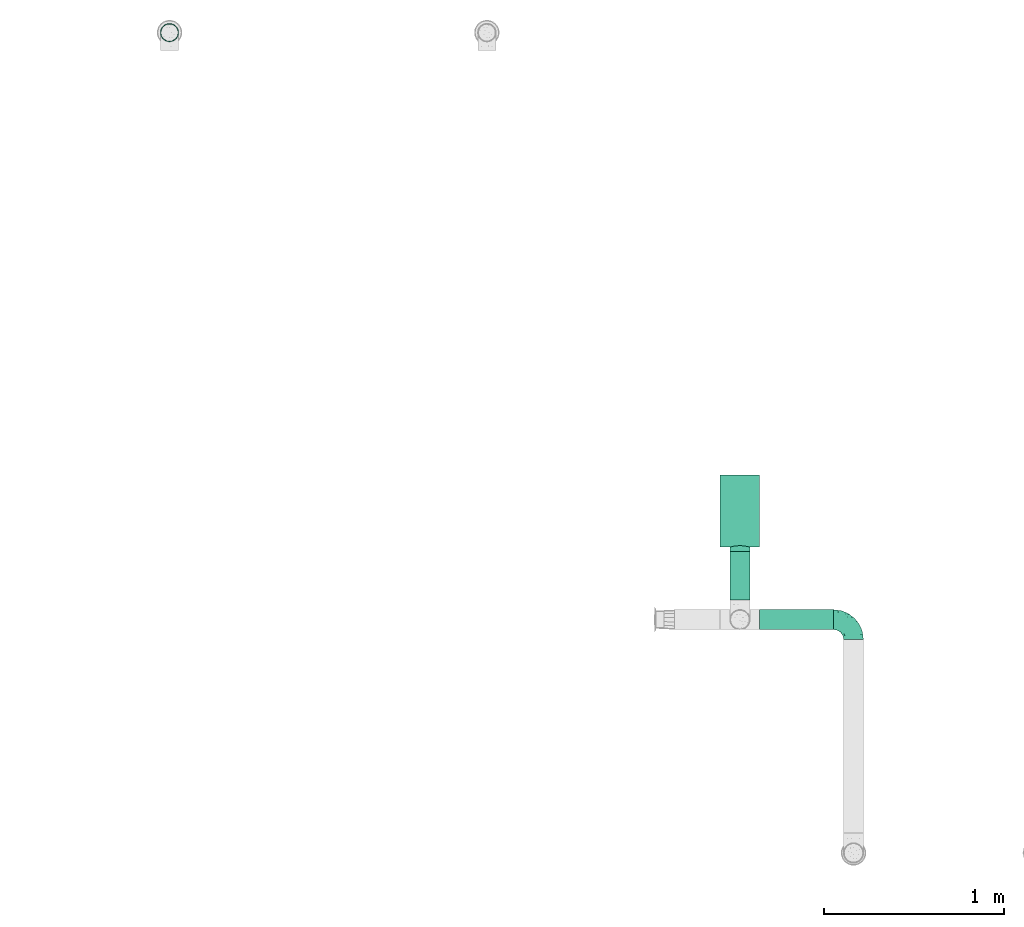
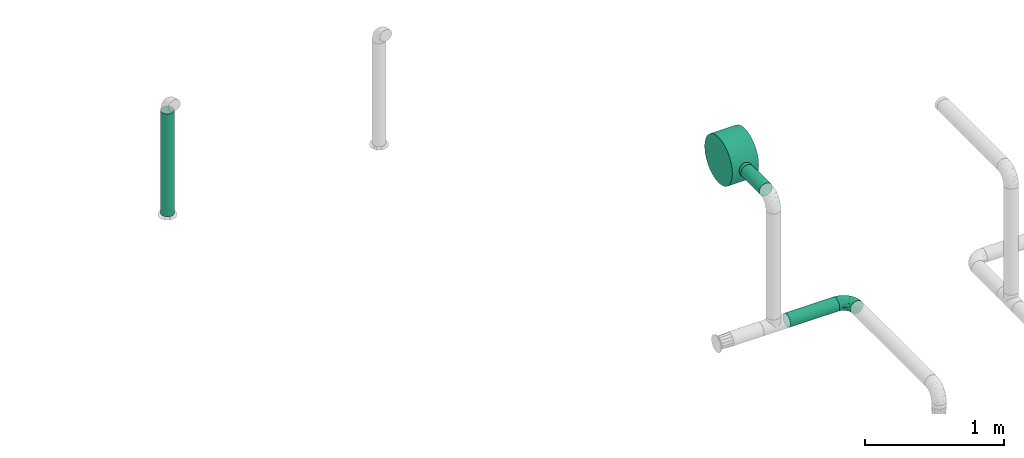
# One storey, part 86 of 103: 3 flow segments, 2 flow fittings.
"""IFC2X3 building model written with IfcOpenShell, lengths in millimetres."""

from ifc_helpers import new_model, entity, si_unit, converted_unit, derived_unit, direction, frame, origin_with_axes, origin_2d_with_axis, place, context, subcontext, project, spatial, hollow_circle, extrude, open_shell, surface_model, source, transform, mapped, material, layer, layer_set, layer_usage, type_object, element, save


model = new_model("IFC2X3")

# Units and contexts
model_context = context("Model", 3, precision=1e-05, world=origin_with_axes(), true_north=direction((0.0, 1.0)))
body_context = subcontext(model_context, "Body", "Model", "MODEL_VIEW")
ifc_project = project(units=[si_unit("AREAUNIT", "SQUARE_METRE"), si_unit("VOLUMEUNIT", "CUBIC_METRE", prefix="DECI"), si_unit("TIMEUNIT", "SECOND"), si_unit("THERMODYNAMICTEMPERATUREUNIT", "DEGREE_CELSIUS"), si_unit("PRESSUREUNIT", "PASCAL"), si_unit("MASSUNIT", "GRAM", prefix="KILO"), si_unit("LENGTHUNIT", "METRE", prefix="MILLI"), si_unit("POWERUNIT", "WATT"), si_unit("ELECTRICCURRENTUNIT", "AMPERE"), si_unit("ELECTRICVOLTAGEUNIT", "VOLT"), derived_unit("VOLUMETRICFLOWRATEUNIT", [(si_unit("VOLUMEUNIT", "CUBIC_METRE", prefix="DECI"), 1), (si_unit("TIMEUNIT", "SECOND"), -1)]), derived_unit("LINEARVELOCITYUNIT", [(si_unit("LENGTHUNIT", "METRE"), 1), (si_unit("TIMEUNIT", "SECOND"), -1)]), derived_unit("MASSDENSITYUNIT", [(si_unit("MASSUNIT", "GRAM", prefix="KILO"), 1), (si_unit("VOLUMEUNIT", "CUBIC_METRE"), -1)]), converted_unit("PLANEANGLEUNIT", "DEGREE", entity("IfcRatioMeasure", 0.01745), si_unit("PLANEANGLEUNIT", "RADIAN"), dimensions=[0, 0, 0, 0, 0, 0, 0])], contexts=[model_context])

# Site, building, storey
site_placement = place(None, origin_with_axes())
site = spatial("IfcSite", under=ifc_project, at=site_placement, CompositionType="ELEMENT")
building_placement = place(site_placement, origin_with_axes())
building = spatial("IfcBuilding", under=site, at=building_placement, Name="mc-building", CompositionType="ELEMENT")
storey_placement = place(building_placement, frame((0.0, 0.0, 5900.0), z_axis=(0.0, 0.0, 1.0), x_axis=(1.0, 0.0, 0.0)))
storey = spatial("IfcBuildingStorey", under=building, at=storey_placement, Name="3. Korrus", CompositionType="ELEMENT", Elevation=5900.0)

# Flow fitting
duct_fitting_type_1 = type_object("IfcDuctFittingType", Name="BU", PredefinedType="BEND")
shared_shape_1 = source(origin_with_axes(), body_context, "Body", "SurfaceModel", [
    surface_model("IfcShellBasedSurfaceModel", [(-110.0, 0.0, -55.0), (-110.0, -14.23505, -53.12592), (-110.0, 14.23505, -53.12592), (-110.0, 53.12592, 14.23505), (-110.0, 27.5, -47.63139), (-110.0, 38.89087, -38.89087), (-110.0, -55.0, 0.0), (-110.0, -53.12592, 14.23505), (-110.0, -38.89087, -38.89087), (-110.0, -27.5, -47.63139), (-110.0, -53.12592, -14.23505), (-110.0, -47.63139, -27.5), (-110.0, -14.23505, 53.12592), (-110.0, 14.23505, 53.12592), (-110.0, 27.5, 47.63139), (-110.0, -47.63139, 27.5), (-110.0, -38.89087, 38.89087), (-110.0, -27.5, 47.63139), (-110.0, 0.0, 55.0), (-110.0, 55.0, 0.0), (-110.0, 53.12592, -14.23505), (-110.0, 47.63139, -27.5), (-110.0, 47.63139, 27.5), (-110.0, 38.89087, 38.89087), (-14.23505, 110.0, -53.12592), (-55.0, 110.0, 0.0), (0.0, 110.0, -55.0), (-27.5, 110.0, -47.63139), (-38.89087, 110.0, -38.89087), (-47.63139, 110.0, -27.5), (38.89087, 110.0, -38.89087), (53.12592, 110.0, 14.23505), (27.5, 110.0, -47.63139), (14.23505, 110.0, -53.12592), (47.63139, 110.0, -27.5), (53.12592, 110.0, -14.23505), (55.0, 110.0, 0.0), (-53.12592, 110.0, -14.23505), (-53.12592, 110.0, 14.23505), (-47.63139, 110.0, 27.5), (-38.89087, 110.0, 38.89087), (-27.5, 110.0, 47.63139), (0.0, 110.0, 55.0), (-14.23505, 110.0, 53.12592), (38.89087, 110.0, 38.89087), (47.63139, 110.0, 27.5), (27.5, 110.0, 47.63139), (14.23505, 110.0, 53.12592), (-64.21732, 48.68956, 43.63444), (-76.6405, 38.18013, 45.55988), (-60.44912, 32.56953, 51.94617), (-76.00813, 5.38378, 55.0), (-90.15553, 11.94394, 54.09138), (-78.5998, 26.77405, 50.81338), (-70.18771, 18.55163, 54.03432), (-75.55424, 54.2118, 32.41257), (-93.27622, 45.77614, 33.48188), (-96.12334, 22.13664, 50.81337), (-21.00813, 45.34362, 55.0), (-18.36258, 70.48427, 54.04484), (-32.04182, 59.64019, 52.24446), (-63.88653, 74.77858, 17.99134), (-74.66383, 63.08407, 19.92123), (-63.60674, 66.07878, 29.97482), (-99.597, 52.72185, 18.52927), (-93.11138, 56.59448, 10.50359), (-98.21577, 57.34403, 0.0), (-53.42855, 92.60092, 21.04759), (-88.54852, 54.8376, 21.04759), (-11.86161, 90.23965, 54.10313), (-5.38378, 76.00813, 55.0), (-57.34403, 98.21577, 0.0), (-56.64619, 93.12774, 10.22088), (-45.34362, 21.00813, 55.0), (-44.60838, 44.60838, 52.13415), (-92.68484, 35.46673, 43.63443), (-22.25266, 95.40765, 50.81337), (-35.97783, 90.61597, 43.63443), (-43.70931, 69.58671, 44.47149), (-27.23711, 77.39884, 50.81337), (-57.2828, 79.3123, 24.9774), (-58.67786, 84.31125, 16.04456), (-82.93277, 60.36161, 12.91784), (-49.88337, 54.51816, 47.224), (-74.57753, 66.83759, 9.55742), (-45.35812, 94.97281, 33.48188), (-59.18663, 88.95241, 0.0), (-51.517, 78.6292, 33.48188), (-65.14788, 80.03077, 0.0), (-56.45322, 62.06476, 39.63545), (-88.95241, 59.18663, 0.0), (-71.10913, 71.10913, 0.0), (-80.03077, 65.14788, 0.0), (-94.9309, 45.36788, -33.48188), (-93.11358, 56.60141, -10.46614), (-99.64997, 52.79499, -18.30015), (-90.20425, 36.08686, -43.63443), (-79.99933, 46.56772, -37.92748), (-76.00813, 5.38378, -55.0), (-72.75364, 19.68651, -53.60527), (-45.34362, 21.00813, -55.0), (-21.91957, 65.12078, -53.85897), (-5.38378, 76.00813, -55.0), (-21.00813, 45.34362, -55.0), (-35.41876, 92.89265, -43.63443), (-91.10309, 11.02766, -54.21832), (-45.77614, 93.27622, -33.48188), (-90.50474, 23.21022, -50.81337), (-70.92854, 33.31794, -49.51754), (-78.52933, 63.35627, -11.73997), (-24.91508, 84.05606, -50.81337), (-88.78941, 54.74452, -21.04759), (-69.59921, 57.34866, -33.48187), (-73.36422, 62.46673, -22.94182), (-63.49062, 67.59111, -28.46929), (-56.59448, 93.11138, -10.50359), (-54.8376, 88.54852, -21.04759), (-54.10679, 75.85581, -32.31867), (-57.75956, 31.09612, -52.80882), (-52.72185, 99.597, -18.52927), (-12.62913, 89.46304, -53.99097), (-34.46825, 66.46123, -50.04329), (-43.9837, 43.9837, -52.42279), (-65.78527, 72.58348, -17.68796), (-70.34468, 43.65295, -44.21951), (-57.47001, 51.99467, -44.91465), (-60.72547, 82.29174, -12.88567), (-42.34915, 74.24548, -43.63444), (-57.25194, 63.5016, -38.08211), (-80.95344, 53.56991, -29.32027), (-52.32891, 4.55257, -54.0482), (32.52942, 47.13398, -30.48571), (14.88266, 20.92917, -33.7947), (14.95561, 36.05775, -42.26543), (30.24048, 70.09027, -41.7461), (19.3559, 65.35825, -48.00507), (-70.35075, -46.44478, -19.5952), (-47.13398, -32.52942, -30.48571), (-28.49299, -30.5778, -16.4009), (-4.55257, 52.32891, -54.0482), (-22.4954, 22.4954, -53.25347), (-75.47368, -11.22546, -52.60718), (-81.32209, -51.5606, -9.98467), (-80.81763, -41.84862, -32.14655), (-70.09027, -30.24048, -41.7461), (-36.05774, -14.95561, -42.26543), (-9.15831, -10.852, -27.8997), (-65.35825, -19.3559, -48.00507), (11.22546, 75.47368, -52.60718), (3.94376, 43.9333, -50.53315), (-13.39742, 13.39743, -48.13058), (-43.9333, -3.94376, -50.53315), (49.37776, 67.29486, 0.0), (41.8609, 47.82256, -9.92641), (50.20582, 74.51695, -9.9731), (18.93131, 11.7156, -17.56239), (-27.5, -32.89419, 0.0), (-1.23348, -12.25375, -12.18106), (41.84862, 80.81763, -32.14655), (35.70604, 41.31408, -20.38235), (46.44478, 70.35075, -19.5952), (32.89419, 27.5, 0.0), (6.67262, -6.67262, 0.0), (-67.29486, -49.37776, 0.0), (-50.36265, -42.95545, -9.51562), (-5.47251, 5.47251, -39.92906), (-70.35075, -46.44478, 19.5952), (-74.51695, -50.20582, 9.9731), (-41.31407, -35.70604, 20.38235), (-47.13398, -32.52942, 30.48571), (-80.81763, -41.84862, 32.14655), (-4.55257, 52.32891, 54.0482), (11.22546, 75.47368, 52.60718), (-43.9333, -3.94376, 50.53315), (-65.35825, -19.3559, 48.00507), (-36.05774, -14.95561, 42.26543), (-70.09027, -30.24048, 41.7461), (-11.7156, -18.93131, 17.56239), (30.5778, 28.49299, 16.4009), (12.25375, 1.23348, 12.18106), (51.5606, 81.32209, 9.98467), (42.95545, 50.36265, 9.51562), (-75.47368, -11.22546, 52.60718), (-52.32891, 4.55257, 54.0482), (3.94376, 43.9333, 50.53315), (-22.4954, 22.4954, 53.25347), (-13.39742, 13.39743, 48.13058), (10.852, 9.15831, 27.8997), (-20.92916, -14.88266, 33.79469), (-47.82256, -41.8609, 9.92641), (32.52942, 47.13398, 30.48571), (46.44478, 70.35075, 19.5952), (41.84862, 80.81763, 32.14655), (30.24048, 70.09027, 41.7461), (19.3559, 65.35825, 48.00507), (14.95561, 36.05775, 42.26543), (-5.47251, 5.47251, 39.92906)], [open_shell([[[0, 1, 2]], [[2, 3, 4]], [[4, 3, 5]], [[2, 6, 7]], [[8, 6, 9]], [[1, 9, 6]], [[10, 6, 11]], [[8, 11, 6]], [[6, 2, 1]], [[12, 13, 14]], [[15, 2, 7]], [[16, 17, 2]], [[2, 17, 12]], [[12, 18, 13]], [[19, 20, 3]], [[5, 3, 21]], [[20, 21, 3]], [[22, 3, 2]], [[23, 22, 2]], [[12, 14, 2]], [[2, 14, 23]], [[15, 16, 2]], [[24, 25, 26]], [[27, 25, 24]], [[25, 28, 29]], [[28, 25, 27]], [[30, 26, 31]], [[26, 30, 32]], [[32, 33, 26]], [[34, 31, 35]], [[31, 34, 30]], [[35, 31, 36]], [[29, 37, 25]], [[38, 39, 26]], [[39, 40, 26]], [[41, 42, 40]], [[42, 26, 40]], [[42, 41, 43]], [[26, 44, 45]], [[31, 26, 45]], [[26, 46, 44]], [[47, 46, 26]], [[42, 47, 26]], [[25, 38, 26]], [[48, 49, 50]], [[18, 51, 52]], [[53, 54, 50]], [[55, 56, 49]], [[56, 22, 23]], [[13, 57, 14]], [[58, 59, 60]], [[61, 62, 63]], [[3, 64, 65]], [[53, 52, 54]], [[3, 65, 66]], [[67, 39, 38]], [[56, 68, 64]], [[65, 64, 68]], [[69, 59, 70]], [[38, 71, 72]], [[73, 58, 74]], [[75, 49, 56]], [[76, 69, 43]], [[53, 57, 52]], [[77, 78, 79]], [[41, 76, 43]], [[43, 69, 42]], [[55, 68, 56]], [[23, 14, 75]], [[76, 77, 79]], [[80, 67, 81]], [[62, 82, 68]], [[60, 78, 83]], [[62, 84, 82]], [[85, 77, 40]], [[81, 67, 72]], [[86, 72, 71]], [[87, 85, 67]], [[61, 81, 88]], [[77, 41, 40]], [[78, 77, 87]], [[23, 75, 56]], [[83, 89, 48]], [[85, 40, 39]], [[62, 68, 55]], [[89, 87, 63]], [[83, 48, 50]], [[57, 75, 14]], [[49, 75, 53]], [[67, 85, 39]], [[87, 77, 85]], [[63, 62, 55]], [[89, 55, 48]], [[80, 63, 87]], [[66, 65, 90]], [[66, 19, 3]], [[84, 91, 92]], [[92, 90, 82]], [[65, 82, 90]], [[61, 84, 62]], [[92, 82, 84]], [[68, 82, 65]], [[3, 22, 64]], [[56, 64, 22]], [[38, 25, 71]], [[81, 72, 86]], [[38, 72, 67]], [[91, 61, 88]], [[80, 81, 61]], [[63, 80, 61]], [[67, 80, 87]], [[77, 76, 41]], [[79, 59, 69]], [[79, 69, 76]], [[42, 69, 70]], [[60, 59, 79]], [[58, 70, 59]], [[78, 60, 79]], [[58, 60, 74]], [[52, 57, 13]], [[75, 57, 53]], [[18, 52, 13]], [[52, 51, 54]], [[51, 73, 54]], [[50, 73, 74]], [[73, 50, 54]], [[50, 74, 83]], [[60, 83, 74]], [[89, 83, 78]], [[87, 89, 78]], [[55, 89, 63]], [[50, 49, 53]], [[55, 49, 48]], [[81, 86, 88]], [[91, 84, 61]], [[5, 21, 93]], [[90, 94, 66]], [[20, 94, 95]], [[96, 93, 97]], [[98, 99, 100]], [[96, 4, 5]], [[101, 102, 103]], [[28, 27, 104]], [[2, 105, 0]], [[104, 106, 28]], [[99, 105, 107]], [[108, 107, 96]], [[90, 109, 94]], [[107, 2, 4]], [[20, 66, 94]], [[27, 24, 110]], [[109, 111, 94]], [[112, 113, 114]], [[37, 115, 71]], [[116, 106, 117]], [[99, 118, 100]], [[116, 115, 119]], [[37, 119, 115]], [[24, 120, 110]], [[121, 110, 101]], [[119, 106, 116]], [[101, 110, 120]], [[122, 103, 100]], [[117, 123, 116]], [[124, 125, 108]], [[115, 116, 126]], [[106, 29, 28]], [[26, 102, 120]], [[127, 104, 110]], [[97, 124, 96]], [[125, 122, 118]], [[128, 127, 125]], [[96, 5, 93]], [[115, 126, 86]], [[117, 106, 127]], [[111, 113, 129]], [[95, 93, 21]], [[97, 129, 112]], [[110, 104, 27]], [[106, 104, 127]], [[96, 107, 4]], [[99, 107, 108]], [[99, 108, 118]], [[105, 99, 98]], [[112, 114, 128]], [[121, 125, 127]], [[20, 19, 66]], [[109, 90, 92]], [[94, 111, 95]], [[91, 123, 109]], [[129, 113, 112]], [[93, 95, 111]], [[21, 20, 95]], [[71, 115, 86]], [[71, 25, 37]], [[123, 91, 88]], [[126, 116, 123]], [[123, 88, 126]], [[86, 126, 88]], [[37, 29, 119]], [[106, 119, 29]], [[129, 93, 111]], [[124, 112, 125]], [[0, 105, 98]], [[107, 105, 2]], [[125, 118, 108]], [[100, 118, 122]], [[93, 129, 97]], [[113, 111, 109]], [[109, 123, 113]], [[114, 123, 117]], [[123, 114, 113]], [[128, 114, 117]], [[127, 128, 117]], [[112, 128, 125]], [[103, 122, 101]], [[110, 121, 127]], [[101, 122, 121]], [[125, 121, 122]], [[26, 120, 24]], [[101, 120, 102]], [[96, 124, 108]], [[92, 91, 109]], [[112, 124, 97]], [[100, 130, 98]], [[131, 132, 133]], [[32, 134, 135]], [[136, 137, 138]], [[139, 140, 103]], [[98, 141, 0]], [[142, 10, 136]], [[143, 144, 137]], [[6, 10, 142]], [[137, 145, 146]], [[144, 147, 145]], [[143, 136, 11]], [[11, 136, 10]], [[8, 143, 11]], [[148, 149, 139]], [[8, 9, 144]], [[9, 1, 147]], [[130, 141, 98]], [[103, 140, 100]], [[148, 135, 149]], [[150, 151, 140]], [[152, 153, 154]], [[130, 140, 151]], [[148, 26, 33]], [[147, 1, 141]], [[155, 146, 132]], [[156, 138, 157]], [[134, 30, 158]], [[150, 140, 149]], [[158, 30, 34]], [[30, 134, 32]], [[153, 159, 160]], [[131, 160, 159]], [[144, 145, 137]], [[36, 152, 154]], [[146, 138, 137]], [[155, 161, 162]], [[158, 160, 131]], [[133, 149, 135]], [[156, 163, 164]], [[163, 142, 164]], [[139, 103, 102]], [[153, 152, 161]], [[34, 35, 160]], [[162, 157, 155]], [[132, 165, 133]], [[157, 146, 155]], [[140, 130, 100]], [[141, 130, 151]], [[141, 151, 147]], [[141, 1, 0]], [[102, 26, 148]], [[140, 139, 149]], [[102, 148, 139]], [[135, 33, 32]], [[151, 150, 145]], [[9, 147, 144]], [[151, 145, 147]], [[145, 165, 146]], [[135, 148, 33]], [[133, 135, 134]], [[131, 133, 134]], [[133, 165, 150]], [[133, 150, 149]], [[145, 150, 165]], [[132, 131, 159]], [[146, 165, 132]], [[160, 158, 34]], [[134, 158, 131]], [[144, 143, 8]], [[136, 143, 137]], [[155, 153, 161]], [[154, 153, 160]], [[153, 155, 159]], [[132, 159, 155]], [[160, 35, 154]], [[36, 154, 35]], [[164, 136, 138]], [[6, 142, 163]], [[136, 164, 142]], [[156, 164, 138]], [[156, 157, 162]], [[146, 157, 138]], [[15, 7, 166]], [[6, 163, 167]], [[168, 169, 166]], [[166, 169, 170]], [[171, 172, 70]], [[173, 174, 175]], [[17, 176, 174]], [[177, 156, 162]], [[176, 16, 170]], [[170, 16, 15]], [[161, 178, 179]], [[152, 180, 181]], [[182, 173, 183]], [[18, 12, 182]], [[184, 185, 186]], [[183, 185, 73]], [[183, 73, 51]], [[177, 187, 188]], [[189, 168, 166]], [[187, 178, 190]], [[16, 176, 17]], [[161, 152, 181]], [[45, 191, 31]], [[45, 44, 192]], [[192, 191, 45]], [[180, 36, 31]], [[193, 194, 195]], [[46, 47, 194]], [[193, 195, 190]], [[193, 44, 46]], [[172, 42, 70]], [[185, 58, 73]], [[189, 163, 156]], [[163, 189, 167]], [[70, 58, 171]], [[184, 171, 185]], [[169, 188, 175]], [[180, 31, 191]], [[192, 193, 190]], [[191, 190, 178]], [[182, 174, 173]], [[194, 47, 172]], [[190, 195, 187]], [[186, 185, 173]], [[162, 179, 177]], [[188, 196, 175]], [[179, 187, 177]], [[185, 171, 58]], [[172, 171, 184]], [[172, 184, 194]], [[172, 47, 42]], [[51, 18, 182]], [[185, 183, 173]], [[51, 182, 183]], [[174, 12, 17]], [[184, 186, 195]], [[46, 194, 193]], [[184, 195, 194]], [[195, 196, 187]], [[174, 182, 12]], [[175, 174, 176]], [[169, 175, 176]], [[175, 196, 186]], [[175, 186, 173]], [[195, 186, 196]], [[188, 169, 168]], [[187, 196, 188]], [[166, 170, 15]], [[176, 170, 169]], [[193, 192, 44]], [[191, 192, 190]], [[177, 189, 156]], [[167, 189, 166]], [[189, 177, 168]], [[188, 168, 177]], [[166, 7, 167]], [[6, 167, 7]], [[181, 191, 178]], [[36, 180, 152]], [[191, 181, 180]], [[161, 181, 178]], [[161, 179, 162]], [[187, 179, 178]]])]),
])
flow_fitting_1_placement = place(storey_placement, frame((33106.64841, 9477.62755, 2345.0), z_axis=(0.0, 0.0, 1.0), x_axis=(0.0, 1.0, 0.0)))
element("IfcFlowFitting", 1, at=flow_fitting_1_placement, inside=storey, type_object=duct_fitting_type_1, Name="BU", context=body_context, shape_type="MappedRepresentation", body=[
    mapped(shared_shape_1, transform((0.0, 0.0, 0.0), scale=1.0)),
])

# Flow segments
ifc_material = material(Name="FZ1")
ifc_layer = layer(ifc_material, 0.0)
ifc_layer_set = layer_set([ifc_layer], Name="FZ1")
ifc_layer_usage = layer_usage(ifc_layer_set, "AXIS1", "POSITIVE", 0.0)
duct_segment_type = type_object("IfcDuctSegmentType", PredefinedType="RIGIDSEGMENT")
shared_shape_2 = source(origin_with_axes(), body_context, "Body", "SweptSolid", [
    extrude(hollow_circle(Radius=55.0, WallThickness=2.0, at=origin_2d_with_axis()), frame((0.0, 0.0, 0.0), z_axis=(1.0, 0.0, 0.0), x_axis=(0.0, 1.0, 0.0)), (0.0, 0.0, 1.0), 410.1),
])
flow_segment_1_placement = place(storey_placement, frame((32996.64841, 9477.62755, 2345.0), z_axis=(0.0, 0.0, 1.0), x_axis=(-1.0, 0.0, 0.0)))
element("IfcFlowSegment", 2, at=flow_segment_1_placement, inside=storey, type_object=duct_segment_type, material=ifc_layer_usage, context=body_context, shape_type="MappedRepresentation", body=[
    mapped(shared_shape_2, transform((0.0, 0.0, 0.0), scale=1.0)),
])
shared_shape_3 = source(origin_with_axes(), body_context, "Body", "SweptSolid", [
    extrude(hollow_circle(Radius=50.0, WallThickness=2.0, at=origin_2d_with_axis()), frame((0.0, 0.0, 0.0), z_axis=(1.0, 0.0, 0.0), x_axis=(0.0, 1.0, 0.0)), (0.0, 0.0, 1.0), 906.0),
])
flow_segment_2_placement = place(storey_placement, frame((29312.94843, 12733.41275, 2461.97044), z_axis=(1.0, 0.0, 0.0), x_axis=(0.0, 0.0, 1.0)))
element("IfcFlowSegment", 3, at=flow_segment_2_placement, inside=storey, type_object=duct_segment_type, material=ifc_layer_usage, context=body_context, shape_type="MappedRepresentation", body=[
    mapped(shared_shape_3, transform((0.0, 0.0, 0.0), scale=1.0)),
])
shared_shape_4 = source(origin_with_axes(), body_context, "Body", "SweptSolid", [
    extrude(hollow_circle(Radius=55.0, WallThickness=2.0, at=origin_2d_with_axis()), frame((0.0, 0.0, 0.0), z_axis=(1.0, 0.0, 0.0), x_axis=(0.0, 1.0, 0.0)), (0.0, 0.0, 1.0), 267.4),
])
flow_segment_3_placement = place(storey_placement, frame((32476.59509, 9855.05037, 3468.0), z_axis=(0.0, 0.0, 1.0), x_axis=(0.0, -1.0, 0.0)))
element("IfcFlowSegment", 4, at=flow_segment_3_placement, inside=storey, type_object=duct_segment_type, material=ifc_layer_usage, context=body_context, shape_type="MappedRepresentation", body=[
    mapped(shared_shape_4, transform((0.0, 0.0, 0.0), scale=1.0)),
])

# Flow fitting
duct_fitting_type_2 = type_object("IfcDuctFittingType", PredefinedType="JUNCTION")
shared_shape_5 = source(origin_with_axes(), body_context, "Body", "SurfaceModel", [
    surface_model("IfcShellBasedSurfaceModel", [(0.0, -225.0, -55.0), (14.23505, -225.0, -53.12592), (-14.23505, -225.0, -53.12592), (-53.12592, -225.0, 14.23505), (-27.5, -225.0, -47.63139), (-47.63139, -225.0, -27.5), (-38.89087, -225.0, -38.89087), (55.0, -225.0, 0.0), (53.12592, -225.0, 14.23505), (38.89087, -225.0, -38.89087), (27.5, -225.0, -47.63139), (53.12592, -225.0, -14.23505), (47.63139, -225.0, -27.5), (-53.12592, -225.0, -14.23505), (-47.63139, -225.0, 27.5), (-38.89087, -225.0, 38.89087), (14.23505, -225.0, 53.12592), (-27.5, -225.0, 47.63139), (-14.23505, -225.0, 53.12592), (47.63139, -225.0, 27.5), (38.89087, -225.0, 38.89087), (27.5, -225.0, 47.63139), (0.0, -225.0, 55.0), (-55.0, -225.0, 0.0), (0.0, -192.28884, 55.0), (-12.29394, -192.68144, 53.60839), (-23.92751, -193.77184, 49.52246), (-34.31923, -195.32745, 42.97895), (-42.9874, -197.03532, 34.30865), (-49.52973, -198.56533, 23.91246), (-53.61252, -199.6229, 12.27592), (-55.0, -200.0, 0.0), (-49.52091, -198.56313, -23.93071), (-42.97449, -197.0325, -34.32482), (-53.60826, -199.62175, -12.29447), (-34.30293, -195.32458, -42.99196), (-23.90904, -193.76957, -49.53138), (-12.27509, -192.68024, -53.61271), (0.0, -192.28884, -55.0), (12.29394, -192.68144, -53.60839), (23.92751, -193.77184, -49.52246), (34.31923, -195.32745, -42.97895), (42.9874, -197.03532, -34.30865), (49.52973, -198.56533, -23.91246), (53.61252, -199.6229, -12.27592), (55.0, -200.0, 0.0), (49.52973, -198.56533, 23.91246), (42.9874, -197.03532, 34.30865), (53.61252, -199.6229, 12.27592), (34.31923, -195.32745, 42.97895), (23.92751, -193.77184, 49.52246), (12.29394, -192.68144, 53.60839), (-110.0, 0.0, -200.0), (-110.0, -44.50419, -194.98559), (-110.0, 44.50419, -194.98559), (-110.0, 194.98559, 44.50419), (-110.0, 86.77674, -180.19378), (-110.0, 180.19378, -86.77674), (-110.0, 156.36629, -124.69796), (-110.0, 124.69796, -156.36629), (-110.0, -200.0, 0.0), (-110.0, -194.98559, 44.50419), (-110.0, -124.69796, -156.36629), (-110.0, -86.77674, -180.19378), (-110.0, -156.36629, -124.69796), (-110.0, -180.19378, -86.77674), (-110.0, -194.98559, -44.50419), (-110.0, 194.98559, -44.50419), (-110.0, 180.19378, 86.77674), (-110.0, 156.36629, 124.69796), (-110.0, 86.77674, 180.19378), (-110.0, 124.69796, 156.36629), (-110.0, 44.50419, 194.98559), (-110.0, 0.0, 200.0), (-110.0, -156.36629, 124.69796), (-110.0, -180.19378, 86.77674), (-110.0, -86.77674, 180.19378), (-110.0, -44.50419, 194.98559), (-110.0, -124.69796, 156.36629), (-110.0, 200.0, 0.0), (110.0, 0.0, -200.0), (110.0, 44.50419, -194.98559), (110.0, 86.77674, -180.19378), (110.0, 200.0, 0.0), (110.0, 156.36629, -124.69796), (110.0, 180.19378, -86.77674), (110.0, 124.69796, -156.36629), (110.0, -156.36629, -124.69796), (110.0, -194.98559, 44.50419), (110.0, -86.77674, -180.19378), (110.0, -44.50419, -194.98559), (110.0, -124.69796, -156.36629), (110.0, -180.19378, -86.77674), (110.0, -194.98559, -44.50419), (110.0, -200.0, 0.0), (110.0, 194.98559, -44.50419), (110.0, 194.98559, 44.50419), (110.0, 180.19378, 86.77674), (110.0, 156.36629, 124.69796), (110.0, 124.69796, 156.36629), (110.0, 86.77674, 180.19378), (110.0, 44.50419, 194.98559), (110.0, -156.36629, 124.69796), (110.0, -180.19378, 86.77674), (110.0, -124.69796, 156.36629), (110.0, -86.77674, 180.19378), (110.0, -44.50419, 194.98559), (110.0, 0.0, 200.0), (-110.0, -197.4928, -22.25209), (110.0, -197.4928, -22.25209), (110.0, -197.4928, 22.25209), (-110.0, -197.4928, 22.25209)], [open_shell([[[0, 1, 2]], [[2, 3, 4]], [[5, 6, 3]], [[6, 4, 3]], [[2, 7, 8]], [[9, 7, 10]], [[1, 10, 7]], [[11, 7, 12]], [[9, 12, 7]], [[7, 2, 1]], [[5, 3, 13]], [[2, 14, 3]], [[2, 15, 14]], [[2, 16, 17]], [[17, 15, 2]], [[16, 18, 17]], [[2, 8, 19]], [[2, 19, 20]], [[2, 20, 21]], [[16, 2, 21]], [[16, 22, 18]], [[23, 13, 3]], [[22, 24, 25]], [[18, 25, 26]], [[22, 25, 18]], [[17, 27, 15]], [[17, 18, 26]], [[27, 17, 26]], [[28, 29, 14]], [[30, 31, 23]], [[29, 30, 3]], [[15, 28, 14]], [[3, 14, 29]], [[23, 3, 30]], [[28, 15, 27]], [[32, 33, 5]], [[34, 32, 13]], [[31, 34, 23]], [[23, 34, 13]], [[32, 5, 13]], [[33, 6, 5]], [[4, 35, 36]], [[36, 37, 2]], [[38, 0, 37]], [[4, 6, 35]], [[2, 4, 36]], [[37, 0, 2]], [[35, 6, 33]], [[0, 38, 39]], [[1, 39, 40]], [[0, 39, 1]], [[10, 41, 9]], [[10, 1, 40]], [[41, 10, 40]], [[42, 43, 12]], [[44, 45, 7]], [[43, 44, 11]], [[9, 42, 12]], [[11, 12, 43]], [[7, 11, 44]], [[42, 9, 41]], [[46, 47, 19]], [[48, 46, 8]], [[45, 48, 7]], [[7, 48, 8]], [[46, 19, 8]], [[47, 20, 19]], [[21, 49, 50]], [[50, 51, 16]], [[24, 22, 51]], [[20, 49, 21]], [[16, 21, 50]], [[22, 16, 51]], [[49, 20, 47]], [[52, 53, 54]], [[54, 55, 56]], [[55, 57, 58]], [[58, 59, 55]], [[59, 56, 55]], [[54, 60, 61]], [[62, 60, 63]], [[54, 53, 63]], [[60, 64, 65]], [[65, 66, 60]], [[60, 62, 64]], [[63, 60, 54]], [[55, 67, 57]], [[54, 68, 55]], [[54, 69, 68]], [[70, 71, 69]], [[70, 54, 72]], [[70, 69, 54]], [[72, 54, 73]], [[74, 73, 75]], [[54, 61, 75]], [[76, 77, 73]], [[73, 78, 76]], [[74, 78, 73]], [[54, 75, 73]], [[79, 67, 55]], [[80, 81, 82]], [[83, 80, 82]], [[84, 85, 83]], [[83, 86, 84]], [[83, 82, 86]], [[87, 80, 88]], [[80, 89, 90]], [[80, 91, 89]], [[91, 80, 87]], [[87, 88, 92]], [[93, 92, 88]], [[93, 88, 94]], [[85, 95, 83]], [[83, 96, 97]], [[98, 80, 97]], [[98, 99, 100]], [[80, 100, 101]], [[80, 98, 100]], [[80, 101, 102]], [[102, 103, 80]], [[88, 80, 103]], [[104, 102, 101]], [[104, 101, 105]], [[101, 106, 105]], [[101, 107, 106]], [[83, 97, 80]], [[72, 107, 101]], [[70, 101, 100]], [[71, 100, 99]], [[73, 107, 72]], [[72, 101, 70]], [[100, 71, 70]], [[99, 69, 71]], [[68, 98, 97]], [[55, 97, 96]], [[79, 96, 83]], [[69, 98, 68]], [[68, 97, 55]], [[96, 79, 55]], [[98, 69, 99]], [[83, 95, 79]], [[85, 84, 58]], [[95, 85, 67]], [[67, 79, 95]], [[58, 57, 85]], [[67, 85, 57]], [[84, 59, 58]], [[56, 86, 82]], [[54, 82, 81]], [[52, 81, 80]], [[59, 86, 56]], [[56, 82, 54]], [[81, 52, 54]], [[86, 59, 84]], [[90, 53, 80]], [[89, 63, 90]], [[65, 87, 92]], [[89, 91, 62]], [[87, 64, 91]], [[92, 40, 39]], [[39, 38, 92]], [[53, 90, 63]], [[62, 63, 89]], [[53, 52, 80]], [[38, 37, 65]], [[34, 108, 32]], [[64, 87, 65]], [[37, 36, 65]], [[64, 62, 91]], [[38, 65, 92]], [[42, 109, 43]], [[93, 42, 41]], [[93, 109, 42]], [[41, 40, 93]], [[93, 40, 92]], [[94, 45, 44]], [[43, 109, 44]], [[44, 109, 94]], [[36, 35, 66]], [[33, 32, 108]], [[33, 66, 35]], [[36, 66, 65]], [[34, 60, 108]], [[31, 60, 34]], [[108, 66, 33]], [[45, 94, 48]], [[94, 110, 48]], [[110, 47, 46]], [[47, 110, 88]], [[49, 47, 88]], [[29, 111, 30]], [[60, 31, 30]], [[111, 60, 30]], [[27, 26, 61]], [[61, 111, 28]], [[61, 28, 27]], [[26, 75, 61]], [[49, 88, 50]], [[51, 103, 24]], [[48, 110, 46]], [[51, 50, 103]], [[74, 103, 102]], [[103, 50, 88]], [[105, 106, 77]], [[76, 104, 105]], [[78, 102, 104]], [[73, 106, 107]], [[25, 24, 75]], [[28, 111, 29]], [[75, 24, 103]], [[74, 75, 103]], [[25, 75, 26]], [[102, 78, 74]], [[104, 76, 78]], [[77, 76, 105]], [[106, 73, 77]]])]),
])
flow_fitting_2_placement = place(storey_placement, frame((32476.59509, 10080.05037, 3468.0), z_axis=(0.0, 0.0, 1.0), x_axis=(1.0, 0.0, 0.0)))
element("IfcFlowFitting", 5, at=flow_fitting_2_placement, inside=storey, type_object=duct_fitting_type_2, context=body_context, shape_type="MappedRepresentation", body=[
    mapped(shared_shape_5, transform((0.0, 0.0, 0.0), scale=1.0)),
])

save(model, "model.ifc")
